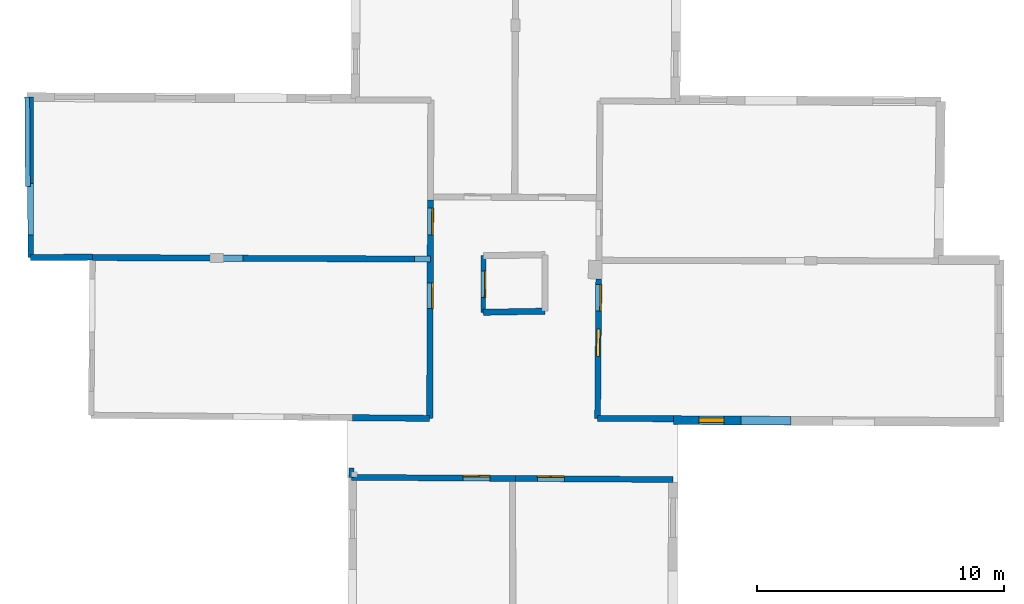
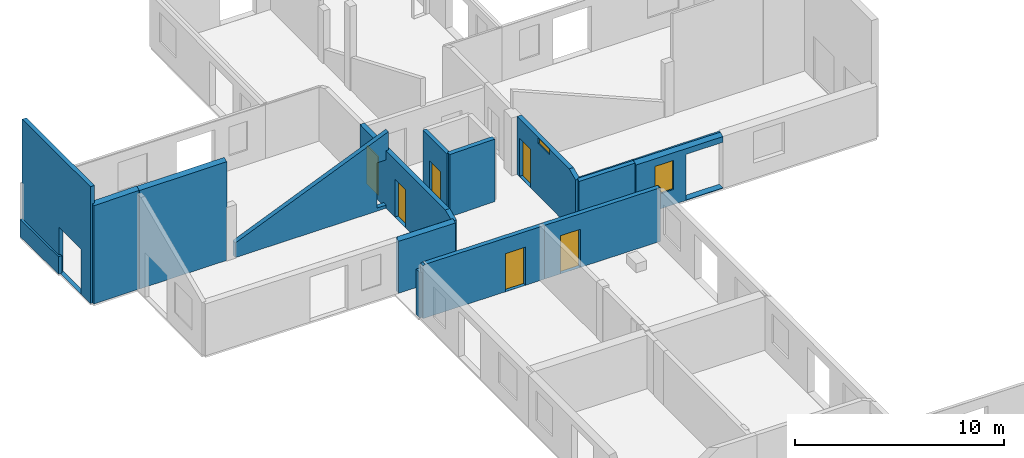
# One storey, part 6 of 10: 15 walls, 6 doors, 2 windows, 11 openings.
"""IFC2X3 building model written with IfcOpenShell, lengths in metres."""

from ifc_helpers import new_model, entity, si_unit, converted_unit, derived_unit, direction, frame, frame_2d, origin, origin_2d_with_axis, place, context, subcontext, project, spatial, polyline, rectangle, outline, extrude, clip, halfspace, source, transform, mapped, material, layer, layer_set, layer_usage, type_object, type_shapes, element, fill, save


model = new_model("IFC2X3")

# Units and contexts
model_context = context("Model", 3, precision=1e-05, world=origin(), true_north=direction((0.0, 1.0)))
body_context = subcontext(model_context, "Body", "Model", "MODEL_VIEW")
ifc_project = project(units=[si_unit("LENGTHUNIT", "METRE"), si_unit("AREAUNIT", "SQUARE_METRE"), si_unit("VOLUMEUNIT", "CUBIC_METRE"), converted_unit("PLANEANGLEUNIT", "DEGREE", entity("IfcRatioMeasure", 0.0174532925199433), si_unit("PLANEANGLEUNIT", "RADIAN"), dimensions=[0, 0, 0, 0, 0, 0, 0]), si_unit("MASSUNIT", "GRAM", prefix="KILO"), derived_unit("MASSDENSITYUNIT", [(si_unit("MASSUNIT", "GRAM", prefix="KILO"), 1), (si_unit("LENGTHUNIT", "METRE"), -3)]), derived_unit("MOMENTOFINERTIAUNIT", [(si_unit("LENGTHUNIT", "METRE"), 4)]), si_unit("TIMEUNIT", "SECOND"), si_unit("FREQUENCYUNIT", "HERTZ"), si_unit("THERMODYNAMICTEMPERATUREUNIT", "DEGREE_CELSIUS"), derived_unit("THERMALTRANSMITTANCEUNIT", [(si_unit("MASSUNIT", "GRAM", prefix="KILO"), 1), (si_unit("THERMODYNAMICTEMPERATUREUNIT", "KELVIN"), -1), (si_unit("TIMEUNIT", "SECOND"), -3)]), derived_unit("VOLUMETRICFLOWRATEUNIT", [(si_unit("LENGTHUNIT", "METRE"), 3), (si_unit("TIMEUNIT", "SECOND"), -1)]), si_unit("ELECTRICCURRENTUNIT", "AMPERE"), si_unit("ELECTRICVOLTAGEUNIT", "VOLT"), si_unit("POWERUNIT", "WATT"), si_unit("FORCEUNIT", "NEWTON", prefix="KILO"), si_unit("ILLUMINANCEUNIT", "LUX"), si_unit("LUMINOUSFLUXUNIT", "LUMEN"), si_unit("LUMINOUSINTENSITYUNIT", "CANDELA"), derived_unit("USERDEFINED", [(si_unit("MASSUNIT", "GRAM", prefix="KILO"), -1), (si_unit("LENGTHUNIT", "METRE"), -2), (si_unit("TIMEUNIT", "SECOND"), 3), (si_unit("LUMINOUSFLUXUNIT", "LUMEN"), 1)]), derived_unit("LINEARVELOCITYUNIT", [(si_unit("LENGTHUNIT", "METRE"), 1), (si_unit("TIMEUNIT", "SECOND"), -1)]), si_unit("PRESSUREUNIT", "PASCAL"), derived_unit("USERDEFINED", [(si_unit("LENGTHUNIT", "METRE"), -2), (si_unit("MASSUNIT", "GRAM", prefix="KILO"), 1), (si_unit("TIMEUNIT", "SECOND"), -2)]), derived_unit("LINEARFORCEUNIT", [(si_unit("MASSUNIT", "GRAM", prefix="KILO"), 1), (si_unit("LENGTHUNIT", "METRE"), 1), (si_unit("TIMEUNIT", "SECOND"), -2), (si_unit("LENGTHUNIT", "METRE"), -1)]), derived_unit("PLANARFORCEUNIT", [(si_unit("MASSUNIT", "GRAM", prefix="KILO"), 1), (si_unit("LENGTHUNIT", "METRE"), 1), (si_unit("TIMEUNIT", "SECOND"), -2), (si_unit("LENGTHUNIT", "METRE"), -2)])], contexts=[model_context])

# Site, building, storey
placement = place(None, origin())
site = spatial("IfcSite", under=ifc_project, at=placement, CompositionType="ELEMENT")
building = spatial("IfcBuilding", under=site, at=placement, CompositionType="ELEMENT")
storey_placement = place(placement, frame((0.0, 0.0, 15.2695512771606)))
storey = spatial("IfcBuildingStorey", under=building, at=storey_placement, Name="Level 6", CompositionType="ELEMENT", Elevation=15.2695512771606)

# Wall, opening
ifc_material_1 = material(Name="Default wall")
ifc_layer_1 = layer(ifc_material_1, 0.25)
ifc_layer_set_1 = layer_set([ifc_layer_1], Name="wall_thickness_0.2500")
ifc_layer_usage_1 = layer_usage(ifc_layer_set_1, "AXIS2", "POSITIVE", -0.125)
wall_type_1 = type_object("IfcWallType", Name="wall_thickness_0.2500", PredefinedType="STANDARD", material=ifc_layer_set_1)
wall_1_placement = place(storey_placement, frame((-5.45814290212712, 57.6854847056886, 0.0), z_axis=(0.0, 0.0, 1.0), x_axis=(0.999990926304691, -0.00425996576104697, 0.0)))
wall_1 = element("IfcWallStandardCase", 1, at=wall_1_placement, inside=storey, type_object=wall_type_1, material=ifc_layer_usage_1, Name="Wall:124", ObjectType="Wall", context=body_context, shape_type="Clipping", body=[
    clip(clip(extrude(outline(polyline([(8.41568381374332, -0.125), (8.41568381374332, 0.125), (0.0, 0.125), (0.0, -0.125), (8.41568381374332, -0.125)])), origin(), (0.0, 0.0, 1.0), 4.78644847869873), halfspace(frame((-7.29547954108924, 0.0906657123078943, 5.82614615592769), z_axis=(-0.00222186381750111, -0.391123444363312, 0.920335544565435), x_axis=(0.999992144121975, -0.0038900662502964, 0.00076097234127326)), False)), halfspace(frame((4.11795020620954, 18.1760259506787, 2.60439273833051), z_axis=(-0.389900695831611, -0.000246536223124187, 0.920856876289642), x_axis=(0.92085458158245, -0.00162420378647146, 0.389902810378011)), False)),
])
opening_1_placement = place(wall_1_placement, frame((7.77499746978737, -0.125, 0.182449340820312)))
element("IfcOpeningElement", 2, at=opening_1_placement, cuts=wall_1, Name="Opening : 700 x 2640 : 116", ObjectType="Opening", context=body_context, shape_type="SweptSolid", body=[
    extrude(rectangle(XDim=0.7, YDim=2.64, at=frame_2d((1.32, 0.35), x_axis=(0.0, 1.0))), frame((0.0, 0.0, 0.0), z_axis=(0.0, 1.0, 0.0), x_axis=(0.0, 0.0, 1.0)), (0.0, 0.0, 1.0), 0.25),
])

# Walls
wall_2_placement = place(storey_placement, frame((-10.7363566501437, 57.7117623801491, 0.0), z_axis=(0.0, 0.0, 1.0), x_axis=(0.999992757788149, -0.00380583384445746, 0.0)))
element("IfcWallStandardCase", 3, at=wall_2_placement, inside=storey, type_object=wall_type_1, material=ifc_layer_usage_1, Name="Wall:128", ObjectType="Wall", context=body_context, shape_type="Clipping", body=[
    clip(extrude(outline(polyline([(4.8091740807665, -0.125), (4.8091740807665, 0.125), (0.0, 0.125), (0.0, -0.125), (4.8091740807665, -0.125)])), origin(), (0.0, 0.0, 1.0), 6.0254487991333), halfspace(frame((-2.01716208371776, 0.0877893602909646, 5.82614615592769), z_axis=(-0.00239948666767796, -0.391122395003375, 0.920335544565435), x_axis=(0.999990274385646, -0.00434419787951225, 0.000760972341273259)), False)),
])
wall_3_placement = place(storey_placement, frame((-0.199439476809395, 51.2203964259758, 0.0), z_axis=(0.0, 0.0, 1.0), x_axis=(0.99995730007222, -0.00924110557651006, 0.0)))
element("IfcWallStandardCase", 4, at=wall_3_placement, inside=storey, type_object=wall_type_1, material=ifc_layer_usage_1, Name="Wall:132", ObjectType="Wall", context=body_context, shape_type="Clipping", body=[
    clip(clip(extrude(outline(polyline([(3.13230084992645, -0.125), (3.13230084992645, 0.125), (0.0, 0.125), (0.0, -0.125), (3.13230084992645, -0.125)])), origin(), (0.0, 0.0, 1.0), 3.13044834136963), halfspace(frame((-12.614064100038, 6.4705400558989, 5.82614615592769), z_axis=(-0.000273557341234766, -0.391129659545049, 0.920335544565435), x_axis=(0.999999115122448, 0.00109118074430609, 0.000760972341273259)), False)), halfspace(frame((-1.29086343401319, 24.6125289277151, 2.60439273833051), z_axis=(-0.389894630495559, -0.00218872127404273, 0.920856876289642), x_axis=(0.920851247598625, 0.00296281207379735, 0.389902810378011)), False)),
])
wall_4_placement = place(storey_placement, frame((-13.2462948069808, 57.7123764573137, 0.0), z_axis=(0.0, 0.0, 1.0), x_axis=(0.99997601985846, 0.00692529479750018, 0.0)))
element("IfcWallStandardCase", 5, at=wall_4_placement, inside=storey, type_object=wall_type_1, material=ifc_layer_usage_1, Name="Wall:155", ObjectType="Wall", context=body_context, shape_type="Clipping", body=[
    clip(extrude(outline(polyline([(2.5101567439018, -0.125), (2.5101567439018, 0.125), (0.0, 0.125), (0.0, -0.125), (2.5101567439018, -0.125)])), origin(), (0.0, 0.0, 1.0), 6.8064489364624), halfspace(frame((0.493769843857878, 0.0914343219423826, 5.82614615592769), z_axis=(-0.00659647793179073, -0.391074125823149, 0.920335544565435), x_axis=(0.99988607871265, -0.0150748306038692, 0.000760972341273259)), False)),
])
wall_5_placement = place(storey_placement, frame((9.74353387222638, 51.1926938071572, 0.0), z_axis=(0.0, 0.0, 1.0), x_axis=(0.999983960441628, -0.00566382021928686, 0.0)))
element("IfcWallStandardCase", 6, at=wall_5_placement, inside=storey, type_object=wall_type_1, material=ifc_layer_usage_1, Name="Wall:166", ObjectType="Wall", context=body_context, shape_type="Clipping", body=[
    clip(clip(extrude(outline(polyline([(3.07259910307896, -0.125), (3.07259910307896, 0.125), (0.0, 0.125), (0.0, -0.125), (3.07259910307896, -0.125)])), origin(), (0.0, 0.0, 1.0), 3.13044834136963), halfspace(frame((-22.5338065814621, 6.48701090067813, 5.82614615592769), z_axis=(-0.00167277461278169, -0.391126178150401, 0.920335544565435), x_axis=(0.999996619854516, -0.00248620205112851, 0.000760972341273259)), False)), halfspace(frame((2.92543323930538, 26.0609113682751, 3.16730048752112), z_axis=(0.390500001327162, 0.00030792791913728, 0.920602875372374), x_axis=(-0.679896666535609, -0.674119537872206, 0.288623234499112)), False)),
])
wall_6_placement = place(storey_placement, frame((5.10408551946633, 55.492956055986, 0.0), z_axis=(0.0, 0.0, 1.0), x_axis=(0.999831318008885, 0.0183666961812956, 0.0)))
element("IfcWallStandardCase", 7, at=wall_6_placement, inside=storey, type_object=wall_type_1, material=ifc_layer_usage_1, Name="Wall:175", ObjectType="Wall", context=body_context, shape_type="Clipping", body=[
    clip(clip(extrude(outline(polyline([(2.50731132785453, -0.125), (2.50731132785453, 0.125), (0.0, 0.125), (0.0, -0.125), (2.50731132785453, -0.125)])), origin(), (0.0, 0.0, 1.0), 3.64244747161865), halfspace(frame((-17.8117378041751, 2.64186044338294, 5.82614615592769), z_axis=(-0.0110707667478543, -0.390973047067262, 0.920335544565435), x_axis=(0.999648134709952, -0.0265146693739364, 0.00076097234127326)), False)), halfspace(frame((8.11049727015013, 21.5983421981329, 3.16730048752112), z_axis=(0.390394645877985, -0.00907558956320238, 0.920602875372374), x_axis=(-0.695898948082482, -0.657587471417276, 0.288623234499112)), False)),
])

# Wall, openings, doors
wall_7_placement = place(storey_placement, frame((2.96665593290288, 60.0493793928457, 0.0), z_axis=(0.0, 0.0, 1.0), x_axis=(-0.00383036466092248, -0.999992664126375, 0.0)))
wall_7 = element("IfcWallStandardCase", 8, at=wall_7_placement, inside=storey, type_object=wall_type_1, material=ifc_layer_usage_1, Name="Wall:209", ObjectType="Wall", context=body_context, shape_type="Clipping", body=[
    clip(clip(extrude(outline(polyline([(8.85799421086243, -0.125), (8.85799421086243, 0.125), (0.0, 0.125), (0.0, -0.125), (8.85799421086243, -0.125)])), origin(), (0.0, 0.0, 1.0), 3.35544872283936), halfspace(frame((2.30234752210885, -15.711122370553, 5.82614615592769), z_axis=(0.391122453747488, -0.00238989204533461, 0.920335544565435), x_axis=(0.00431966712151528, 0.999990380652262, 0.000760972341273259)), False)), halfspace(frame((-15.7781077853641, -4.28992412244265, 2.60439273833051), z_axis=(7.90330659066921e-05, -0.389900765764647, 0.920856876289642), x_axis=(0.00201980700547796, 0.920853798840505, 0.38990281037801)), False)),
])
opening_2_placement = place(wall_7_placement, frame((3.37444872923663, -0.125, 0.00544929504394531)))
opening_2 = element("IfcOpeningElement", 9, at=opening_2_placement, cuts=wall_7, Name="Opening : 1030 x 2210 : 188", ObjectType="Opening", context=body_context, shape_type="SweptSolid", body=[
    extrude(rectangle(XDim=1.03, YDim=2.21, at=frame_2d((1.105, 0.515), x_axis=(0.0, 1.0))), frame((0.0, 0.0, 0.0), z_axis=(0.0, 1.0, 0.0), x_axis=(0.0, 0.0, 1.0)), (0.0, 0.0, 1.0), 0.25),
])
opening_3_placement = place(wall_7_placement, frame((0.331202069582925, -0.125, 0.00544929504394531)))
opening_3 = element("IfcOpeningElement", 10, at=opening_3_placement, cuts=wall_7, Name="Opening : 1090 x 2255 : 189", ObjectType="Opening", context=body_context, shape_type="SweptSolid", body=[
    extrude(rectangle(XDim=1.09, YDim=2.255, at=frame_2d((1.1275, 0.545), x_axis=(0.0, 1.0))), frame((0.0, 0.0, 0.0), z_axis=(0.0, 1.0, 0.0), x_axis=(0.0, 0.0, 1.0)), (0.0, 0.0, 1.0), 0.25),
])
ifc_material_2 = material(Name="Door Panel")
door_style_1 = type_object("IfcDoorStyle", Name="Door : 1030 x 2210mm", ConstructionType="NOTDEFINED", OperationType="SINGLE_SWING_RIGHT", ParameterTakesPrecedence=False, Sizeable=False, material=ifc_material_2)
shared_shape_1 = source(origin(), body_context, "Body", "SweptSolid", [
    extrude(rectangle(XDim=0.0625, YDim=1.03, at=origin_2d_with_axis()), frame((0.515, 0.21875, 0.0), z_axis=(0.0, 0.0, 1.0), x_axis=(0.0, 1.0, 0.0)), (0.0, 0.0, 1.0), 2.21),
])
type_shapes(door_style_1, [shared_shape_1])
door_1_placement = place(opening_2_placement, origin())
door_1 = element("IfcDoor", 11, at=door_1_placement, inside=storey, type_object=door_style_1, Name="Door : 1030 x 2210mm : 29", ObjectType="Door : 1030 x 2210mm", OverallHeight=2.21, OverallWidth=1.03, context=body_context, shape_type="MappedRepresentation", body=[
    mapped(shared_shape_1, transform((0.0, 0.0, 0.0), scale=1.0)),
])
fill(opening_2, door_1)
door_style_2 = type_object("IfcDoorStyle", Name="Door : 1090 x 2255mm", ConstructionType="NOTDEFINED", OperationType="SINGLE_SWING_RIGHT", ParameterTakesPrecedence=False, Sizeable=False, material=ifc_material_2)
shared_shape_2 = source(origin(), body_context, "Body", "SweptSolid", [
    extrude(rectangle(XDim=0.0625, YDim=1.09, at=origin_2d_with_axis()), frame((0.545, 0.21875, 0.0), z_axis=(0.0, 0.0, 1.0), x_axis=(0.0, 1.0, 0.0)), (0.0, 0.0, 1.0), 2.255),
])
type_shapes(door_style_2, [shared_shape_2])
door_2_placement = place(opening_3_placement, origin())
door_2 = element("IfcDoor", 12, at=door_2_placement, inside=storey, type_object=door_style_2, Name="Door : 1090 x 2255mm : 30", ObjectType="Door : 1090 x 2255mm", OverallHeight=2.255, OverallWidth=1.09, context=body_context, shape_type="MappedRepresentation", body=[
    mapped(shared_shape_2, transform((0.0, 0.0, 0.0), scale=1.0)),
])
fill(opening_3, door_2)

# Wall, opening, door
ifc_layer_2 = layer(ifc_material_1, 0.2)
ifc_layer_set_2 = layer_set([ifc_layer_2], Name="wall_thickness_0.2000")
ifc_layer_usage_2 = layer_usage(ifc_layer_set_2, "AXIS2", "POSITIVE", -0.1)
wall_type_2 = type_object("IfcWallType", Name="wall_thickness_0.2000", PredefinedType="STANDARD", material=ifc_layer_set_2)
wall_8_placement = place(storey_placement, frame((5.11043853564016, 57.787149073771, 0.0), z_axis=(0.0, 0.0, 1.0), x_axis=(-0.00276932861353011, -0.999996165402163, 0.0)))
wall_8 = element("IfcWallStandardCase", 13, at=wall_8_placement, inside=storey, type_object=wall_type_2, material=ifc_layer_usage_2, Name="Wall:144", ObjectType="Wall", context=body_context, shape_type="Clipping", body=[
    clip(clip(extrude(outline(polyline([(2.29419443574076, -0.1), (2.29419443574076, 0.1), (0.0, 0.1), (0.0, -0.1), (2.29419443574076, -0.1)])), origin(), (0.0, 0.0, 1.0), 3.64244747161865), halfspace(frame((0.0293912646829059, -17.8635956547029, 5.82614615592769), z_axis=(0.391119697807693, -0.00280488792347939, 0.920335544565435), x_axis=(0.00538069615835397, 0.999985234405962, 0.000760972341273259)), False)), halfspace(frame((-18.0389354978947, -6.4232197190578, 2.60439273833051), z_axis=(-0.000334667940144517, -0.389900630144981, 0.920856876289642), x_axis=(0.00299687012560561, 0.920851137388003, 0.389902810378011)), False)),
])
opening_4_placement = place(wall_8_placement, frame((0.624922300283537, -0.1, 0.00744915008544922)))
opening_4 = element("IfcOpeningElement", 14, at=opening_4_placement, cuts=wall_8, Name="Opening : 1075 x 2220 : 136", ObjectType="Opening", context=body_context, shape_type="SweptSolid", body=[
    extrude(rectangle(XDim=1.075, YDim=2.22, at=frame_2d((1.11, 0.5375), x_axis=(0.0, 1.0))), frame((0.0, 0.0, 0.0), z_axis=(0.0, 1.0, 0.0), x_axis=(0.0, 0.0, 1.0)), (0.0, 0.0, 1.0), 0.2),
])
door_style_3 = type_object("IfcDoorStyle", Name="Door : 1075 x 2220mm", ConstructionType="NOTDEFINED", OperationType="SINGLE_SWING_RIGHT", ParameterTakesPrecedence=False, Sizeable=False, material=ifc_material_2)
shared_shape_3 = source(origin(), body_context, "Body", "SweptSolid", [
    extrude(rectangle(XDim=0.05, YDim=1.075, at=origin_2d_with_axis()), frame((0.5375, 0.175, 0.0), z_axis=(0.0, 0.0, 1.0), x_axis=(0.0, 1.0, 0.0)), (0.0, 0.0, 1.0), 2.22),
])
type_shapes(door_style_3, [shared_shape_3])
door_3_placement = place(opening_4_placement, origin())
door_3 = element("IfcDoor", 15, at=door_3_placement, inside=storey, type_object=door_style_3, Name="Door : 1075 x 2220mm : 21", ObjectType="Door : 1075 x 2220mm", OverallHeight=2.22, OverallWidth=1.075, context=body_context, shape_type="MappedRepresentation", body=[
    mapped(shared_shape_3, transform((0.0, 0.0, 0.0), scale=1.0)),
])
fill(opening_4, door_3)

# Walls
wall_9_placement = place(storey_placement, frame((-13.3852664732301, 64.2179977342783, 0.0), z_axis=(0.0, 0.0, 1.0), x_axis=(0.00727876496969819, -0.999973509439383, 0.0)))
element("IfcWallStandardCase", 16, at=wall_9_placement, inside=storey, type_object=wall_type_2, material=ifc_layer_usage_2, Name="Wall:158", ObjectType="Wall", context=body_context, shape_type="SweptSolid", body=[
    extrude(outline(polyline([(3.6207776791259, -0.1), (3.6207776791259, 0.1), (0.0, 0.1), (0.0, -0.1), (3.6207776791259, -0.1)])), origin(), (0.0, 0.0, 1.0), 1.01044940948486),
])
wall_10_placement = place(storey_placement, frame((-0.238768791981315, 49.1723850762787, 0.0), z_axis=(0.0, 0.0, 1.0), x_axis=(-0.00142243532654445, -0.999998988338359, 0.0)))
element("IfcWallStandardCase", 17, at=wall_10_placement, inside=storey, type_object=wall_type_2, material=ifc_layer_usage_2, Name="Wall:180", ObjectType="Wall", context=body_context, shape_type="Clipping", body=[
    clip(extrude(outline(polyline([(0.370403664518101, -0.1), (0.370403664518101, 0.1), (0.0, 0.1), (0.0, -0.1), (0.370403664518101, -0.1)])), origin(), (0.0, 0.0, 1.0), 2.63044834136963), halfspace(frame((-26.6699347277104, -1.06196935240693, 2.60439273833051), z_axis=(-0.00085982321225824, -0.389899825716975, 0.920856876289642), x_axis=(0.00423715806538504, 0.920846265644194, 0.389902810378011)), False)),
])

# Wall, openings, door, window
ifc_layer_3 = layer(ifc_material_1, 0.239999994635582)
ifc_layer_set_3 = layer_set([ifc_layer_3], Name="wall_thickness_0.2400")
ifc_layer_usage_3 = layer_usage(ifc_layer_set_3, "AXIS2", "POSITIVE", -0.119999997317791)
wall_type_3 = type_object("IfcWallType", Name="wall_thickness_0.2400", PredefinedType="STANDARD", material=ifc_layer_set_3)
wall_11_placement = place(storey_placement, frame((9.78765610774652, 56.8505313073036, 0.0), z_axis=(0.0, 0.0, 1.0), x_axis=(-0.00779843583247991, -0.999969591736952, 0.0)))
wall_11 = element("IfcWallStandardCase", 18, at=wall_11_placement, inside=storey, type_object=wall_type_3, material=ifc_layer_usage_3, Name="Wall:134", ObjectType="Wall", context=body_context, shape_type="Clipping", body=[
    clip(clip(extrude(outline(polyline([(5.65801277910068, -0.119999997317791), (5.65801277910068, 0.119999997317791), (0.0, 0.119999997317791), (0.0, -0.119999997317791), (5.65801277910068, -0.119999997317791)])), origin(), (0.0, 0.0, 1.0), 3.37544918060303), halfspace(frame((-0.780884503470887, -22.5476014322626, 5.82614615592769), z_axis=(0.391128857820085, -0.000837848315887143, 0.920335544565435), x_axis=(0.000351540845387015, 0.999999648670003, 0.000760972341273259)), False)), halfspace(frame((-20.4090872650465, 2.8697967059659, 3.16730048752112), z_axis=(-0.00114151302686516, 0.390498454291597, 0.920602875372374), x_axis=(0.675569352053961, -0.678456099591316, 0.288623234499112)), False)),
])
opening_5_placement = place(wall_11_placement, frame((0.224993859967357, -0.119999997317791, 0.00744915008544922)))
opening_5 = element("IfcOpeningElement", 19, at=opening_5_placement, cuts=wall_11, Name="Opening : 1080 x 2235 : 123", ObjectType="Opening", context=body_context, shape_type="SweptSolid", body=[
    extrude(rectangle(XDim=1.08, YDim=2.235, at=frame_2d((1.1175, 0.54), x_axis=(0.0, 1.0))), frame((0.0, 0.0, 0.0), z_axis=(0.0, 1.0, 0.0), x_axis=(0.0, 0.0, 1.0)), (0.0, 0.0, 1.0), 0.239999994635582),
])
opening_6_placement = place(wall_11_placement, frame((2.03496634355845, -0.119999997317791, 3.04544925689697)))
opening_6 = element("IfcOpeningElement", 20, at=opening_6_placement, cuts=wall_11, Name="Opening : 1105 x 320 : 124", ObjectType="Opening", context=body_context, shape_type="SweptSolid", body=[
    extrude(rectangle(XDim=1.105, YDim=0.32, at=frame_2d((0.16, 0.5525), x_axis=(0.0, 1.0))), frame((0.0, 0.0, 0.0), z_axis=(0.0, 1.0, 0.0), x_axis=(0.0, 0.0, 1.0)), (0.0, 0.0, 1.0), 0.239999994635582),
])
door_style_4 = type_object("IfcDoorStyle", Name="Door : 1080 x 2235mm", ConstructionType="NOTDEFINED", OperationType="SINGLE_SWING_RIGHT", ParameterTakesPrecedence=False, Sizeable=False, material=ifc_material_2)
shared_shape_4 = source(origin(), body_context, "Body", "SweptSolid", [
    extrude(rectangle(XDim=0.0599999986588955, YDim=1.08, at=origin_2d_with_axis()), frame((0.54, 0.209999995306134, 0.0), z_axis=(0.0, 0.0, 1.0), x_axis=(0.0, 1.0, 0.0)), (0.0, 0.0, 1.0), 2.235),
])
type_shapes(door_style_4, [shared_shape_4])
door_4_placement = place(opening_5_placement, origin())
door_4 = element("IfcDoor", 21, at=door_4_placement, inside=storey, type_object=door_style_4, Name="Door : 1080 x 2235mm : 20", ObjectType="Door : 1080 x 2235mm", OverallHeight=2.235, OverallWidth=1.08, context=body_context, shape_type="MappedRepresentation", body=[
    mapped(shared_shape_4, transform((0.0, 0.0, 0.0), scale=1.0)),
])
fill(opening_5, door_4)
ifc_material_3 = material(Name="Window Default")
window_style_1 = type_object("IfcWindowStyle", Name="Window : 1105 x 320mm", ConstructionType="NOTDEFINED", OperationType="NOTDEFINED", ParameterTakesPrecedence=False, Sizeable=False, material=ifc_material_3)
shared_shape_5 = source(origin(), body_context, "Body", "SweptSolid", [
    extrude(rectangle(XDim=0.119999997317791, YDim=1.105, at=origin_2d_with_axis()), frame((0.5525, 0.119999997317791, 0.0), z_axis=(0.0, 0.0, 1.0), x_axis=(0.0, 1.0, 0.0)), (0.0, 0.0, 1.0), 0.32),
])
type_shapes(window_style_1, [shared_shape_5])
window_1_placement = place(opening_6_placement, origin())
window_1 = element("IfcWindow", 22, at=window_1_placement, inside=storey, type_object=window_style_1, Name="Window : 1105 x 320mm : 70", ObjectType="Window : 1105 x 320mm", OverallHeight=0.32, OverallWidth=1.105, context=body_context, shape_type="MappedRepresentation", body=[
    mapped(shared_shape_5, transform((0.0, 0.0, 0.0), scale=1.0)),
])
fill(opening_6, window_1)

# Wall, opening, door
wall_12_placement = place(storey_placement, frame((-0.23929607242481, 48.8019847957999, 0.0), z_axis=(0.0, 0.0, 1.0), x_axis=(0.999975296463026, -0.00702897315999746, 0.0)))
wall_12 = element("IfcWallStandardCase", 23, at=wall_12_placement, inside=storey, type_object=wall_type_3, material=ifc_layer_usage_3, Name="Wall:156", ObjectType="Wall", context=body_context, shape_type="Clipping", body=[
    clip(extrude(outline(polyline([(6.65688651742884, -0.119999997317791), (6.65688651742884, 0.119999997317791), (0.0, 0.119999997317791), (0.0, -0.119999997317791), (6.65688651742884, -0.119999997317791)])), origin(), (0.0, 0.0, 1.0), 3.13044834136963), halfspace(frame((-1.21355567331619, 27.0339563940472, 2.60439273833051), z_axis=(-0.389898518350457, -0.00132618935385444, 0.920856876289642), x_axis=(0.92085554868849, 0.000925693766492611, 0.389902810378011)), False)),
])
opening_7_placement = place(wall_12_placement, frame((4.52258180409716, -0.119999997317791, 0.00544929504394531)))
opening_7 = element("IfcOpeningElement", 24, at=opening_7_placement, cuts=wall_12, Name="Opening : 1100 x 2220 : 147", ObjectType="Opening", context=body_context, shape_type="SweptSolid", body=[
    extrude(rectangle(XDim=1.1, YDim=2.22, at=frame_2d((1.11, 0.55), x_axis=(0.0, 1.0))), frame((0.0, 0.0, 0.0), z_axis=(0.0, 1.0, 0.0), x_axis=(0.0, 0.0, 1.0)), (0.0, 0.0, 1.0), 0.239999994635582),
])
door_style_5 = type_object("IfcDoorStyle", Name="Door : 1100 x 2220mm", ConstructionType="NOTDEFINED", OperationType="SINGLE_SWING_RIGHT", ParameterTakesPrecedence=False, Sizeable=False, material=ifc_material_2)
shared_shape_6 = source(origin(), body_context, "Body", "SweptSolid", [
    extrude(rectangle(XDim=0.0599999986588955, YDim=1.1, at=origin_2d_with_axis()), frame((0.55, 0.209999995306134, 0.0), z_axis=(0.0, 0.0, 1.0), x_axis=(0.0, 1.0, 0.0)), (0.0, 0.0, 1.0), 2.22),
])
type_shapes(door_style_5, [shared_shape_6])
door_5_placement = place(opening_7_placement, origin())
door_5 = element("IfcDoor", 25, at=door_5_placement, inside=storey, type_object=door_style_5, Name="Door : 1100 x 2220mm : 22", ObjectType="Door : 1100 x 2220mm", OverallHeight=2.22, OverallWidth=1.1, context=body_context, shape_type="MappedRepresentation", body=[
    mapped(shared_shape_6, transform((0.0, 0.0, 0.0), scale=1.0)),
])
fill(opening_7, door_5)

wall_13_placement = place(storey_placement, frame((6.41742599636181, 48.7551937191398, 0.0), z_axis=(0.0, 0.0, 1.0), x_axis=(0.999975303179117, -0.00702801763181057, 0.0)))
wall_13 = element("IfcWallStandardCase", 26, at=wall_13_placement, inside=storey, type_object=wall_type_3, material=ifc_layer_usage_3, Name="Wall:157", ObjectType="Wall", context=body_context, shape_type="Clipping", body=[
    clip(extrude(outline(polyline([(6.38911338389797, -0.119999997317791), (6.38911338389797, 0.119999997317791), (0.0, 0.119999997317791), (0.0, -0.119999997317791), (6.38911338389797, -0.119999997317791)])), origin(), (0.0, 0.0, 1.0), 3.13044834136963), halfspace(frame((6.19877251954364, 28.5256938993682, 3.16730048752112), z_axis=(0.390499217862694, 0.000840657326871799, 0.920602875372374), x_axis=(-0.6789763834215, -0.675046442300921, 0.288623234499112)), False)),
])
opening_8_placement = place(wall_13_placement, frame((0.878957488909093, -0.119999997317791, 0.00644874572753906)))
opening_8 = element("IfcOpeningElement", 27, at=opening_8_placement, cuts=wall_13, Name="Opening : 1100 x 2220 : 148", ObjectType="Opening", context=body_context, shape_type="SweptSolid", body=[
    extrude(rectangle(XDim=1.1, YDim=2.22, at=frame_2d((1.11, 0.55), x_axis=(0.0, 1.0))), frame((0.0, 0.0, 0.0), z_axis=(0.0, 1.0, 0.0), x_axis=(0.0, 0.0, 1.0)), (0.0, 0.0, 1.0), 0.239999994635582),
])
door_6_placement = place(opening_8_placement, origin())
door_6 = element("IfcDoor", 28, at=door_6_placement, inside=storey, type_object=door_style_5, Name="Door : 1100 x 2220mm : 23", ObjectType="Door : 1100 x 2220mm", OverallHeight=2.22, OverallWidth=1.1, context=body_context, shape_type="MappedRepresentation", body=[
    mapped(shared_shape_6, transform((0.0, 0.0, 0.0), scale=1.0)),
])
fill(opening_8, door_6)

# Wall, openings, window
ifc_layer_4 = layer(ifc_material_1, 0.360000014305115)
ifc_layer_set_4 = layer_set([ifc_layer_4], Name="wall_thickness_0.3600")
ifc_layer_usage_4 = layer_usage(ifc_layer_set_4, "AXIS2", "POSITIVE", -0.180000007152557)
wall_type_4 = type_object("IfcWallType", Name="wall_thickness_0.3600", PredefinedType="STANDARD", material=ifc_layer_set_4)
wall_14_placement = place(storey_placement, frame((12.8158674997606, 51.1202958482333, 0.0), z_axis=(0.0, 0.0, 1.0), x_axis=(0.999983960938763, -0.00566373244630483, 0.0)))
wall_14 = element("IfcWallStandardCase", 29, at=wall_14_placement, inside=storey, type_object=wall_type_4, material=ifc_layer_usage_4, Name="Wall:167", ObjectType="Wall", context=body_context, shape_type="Clipping", body=[
    clip(extrude(outline(polyline([(4.76859683904133, -0.180000007152557), (4.76859683904133, 0.180000007152557), (0.0, 0.180000007152557), (0.0, -0.180000007152557), (4.76859683904133, -0.180000007152557)])), origin(), (0.0, 0.0, 1.0), 3.13044834136963), halfspace(frame((-25.6065004049246, 6.54200880064565, 5.82614615592769), z_axis=(-0.00167280894364333, -0.391126178003573, 0.920335544565435), x_axis=(0.999996619636287, -0.00248628982522163, 0.000760972341273259)), False)),
])
opening_9_placement = place(wall_14_placement, frame((2.74240594498967, -0.180000007152557, 0.0304489135742188)))
element("IfcOpeningElement", 30, at=opening_9_placement, cuts=wall_14, Name="Opening : 2110 x 2660 : 151", ObjectType="Opening", context=body_context, shape_type="SweptSolid", body=[
    extrude(rectangle(XDim=2.11, YDim=2.66, at=frame_2d((1.33, 1.055), x_axis=(0.0, 1.0))), frame((0.0, 0.0, 0.0), z_axis=(0.0, 1.0, 0.0), x_axis=(0.0, 0.0, 1.0)), (0.0, 0.0, 1.0), 0.360000014305115),
])
opening_10_placement = place(wall_14_placement, frame((1.03976480423718, -0.180000007152557, 0.880448341369629)))
opening_10 = element("IfcOpeningElement", 31, at=opening_10_placement, cuts=wall_14, Name="Opening : 1015 x 1695 : 152", ObjectType="Opening", context=body_context, shape_type="SweptSolid", body=[
    extrude(rectangle(XDim=1.015, YDim=1.695, at=frame_2d((0.8475, 0.5075), x_axis=(0.0, 1.0))), frame((0.0, 0.0, 0.0), z_axis=(0.0, 1.0, 0.0), x_axis=(0.0, 0.0, 1.0)), (0.0, 0.0, 1.0), 0.360000014305115),
])
window_style_2 = type_object("IfcWindowStyle", Name="Window : 1015 x 1695mm", ConstructionType="NOTDEFINED", OperationType="NOTDEFINED", ParameterTakesPrecedence=False, Sizeable=False, material=ifc_material_3)
shared_shape_7 = source(origin(), body_context, "Body", "SweptSolid", [
    extrude(rectangle(XDim=0.180000007152557, YDim=1.015, at=origin_2d_with_axis()), frame((0.5075, 0.180000007152557, 0.0), z_axis=(0.0, 0.0, 1.0), x_axis=(0.0, 1.0, 0.0)), (0.0, 0.0, 1.0), 1.695),
])
type_shapes(window_style_2, [shared_shape_7])
window_2_placement = place(opening_10_placement, origin())
window_2 = element("IfcWindow", 32, at=window_2_placement, inside=storey, type_object=window_style_2, Name="Window : 1015 x 1695mm : 83", ObjectType="Window : 1015 x 1695mm", OverallHeight=1.695, OverallWidth=1.015, context=body_context, shape_type="MappedRepresentation", body=[
    mapped(shared_shape_7, transform((0.0, 0.0, 0.0), scale=1.0)),
])
fill(opening_10, window_2)

# Wall, opening
ifc_layer_5 = layer(ifc_material_1, 0.230000004172325)
ifc_layer_set_5 = layer_set([ifc_layer_5], Name="wall_thickness_0.2300")
ifc_layer_usage_5 = layer_usage(ifc_layer_set_5, "AXIS2", "POSITIVE", -0.115000002086163)
wall_type_5 = type_object("IfcWallType", Name="wall_thickness_0.2300", PredefinedType="STANDARD", material=ifc_layer_set_5)
wall_15_placement = place(storey_placement, frame((-13.2546700074284, 64.2174484415592, 0.0), z_axis=(0.0, 0.0, 1.0), x_axis=(0.00128733399578099, -0.999999171385248, 0.0)))
wall_15 = element("IfcWallStandardCase", 33, at=wall_15_placement, inside=storey, type_object=wall_type_5, material=ifc_layer_usage_5, Name="Wall:207", ObjectType="Wall", context=body_context, shape_type="SweptSolid", body=[
    extrude(outline(polyline([(6.50508275226808, -0.115000002086163), (6.50508275226808, 0.115000002086163), (0.0, 0.115000002086163), (0.0, -0.115000002086163), (6.50508275226808, -0.115000002086163)])), origin(), (0.0, 0.0, 1.0), 6.8064489364624),
])
opening_11_placement = place(wall_15_placement, frame((3.50109007287388, -0.115000002086163, 0.00544929504394531)))
element("IfcOpeningElement", 34, at=opening_11_placement, cuts=wall_15, Name="Opening : 2090 x 2620 : 187", ObjectType="Opening", context=body_context, shape_type="SweptSolid", body=[
    extrude(rectangle(XDim=2.09, YDim=2.62, at=frame_2d((1.31, 1.045), x_axis=(0.0, 1.0))), frame((0.0, 0.0, 0.0), z_axis=(0.0, 1.0, 0.0), x_axis=(0.0, 0.0, 1.0)), (0.0, 0.0, 1.0), 0.230000004172325),
])

save(model, "model.ifc")
